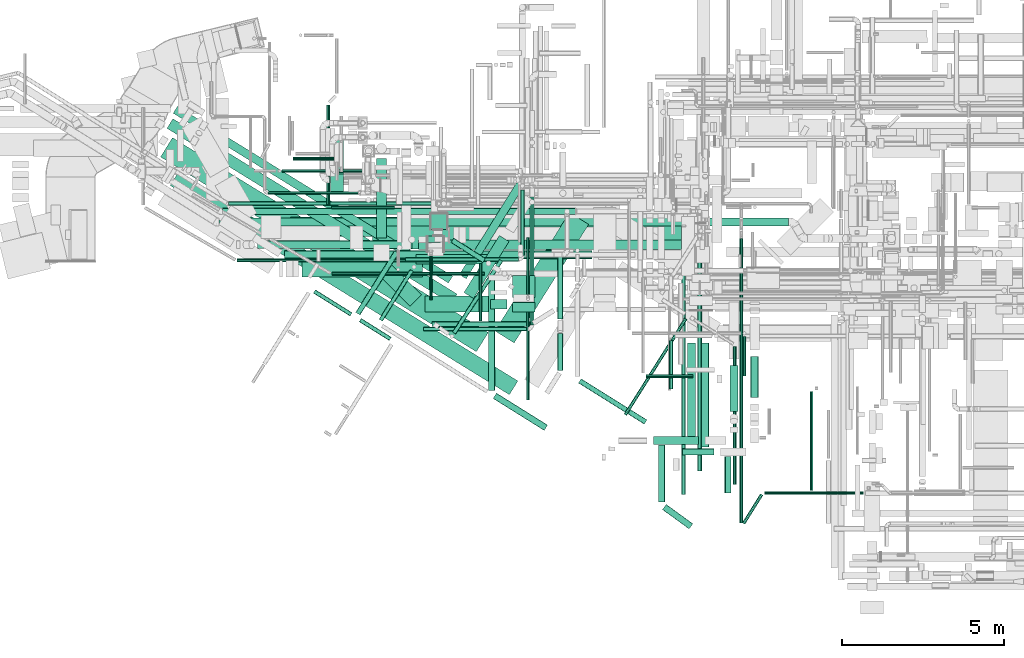
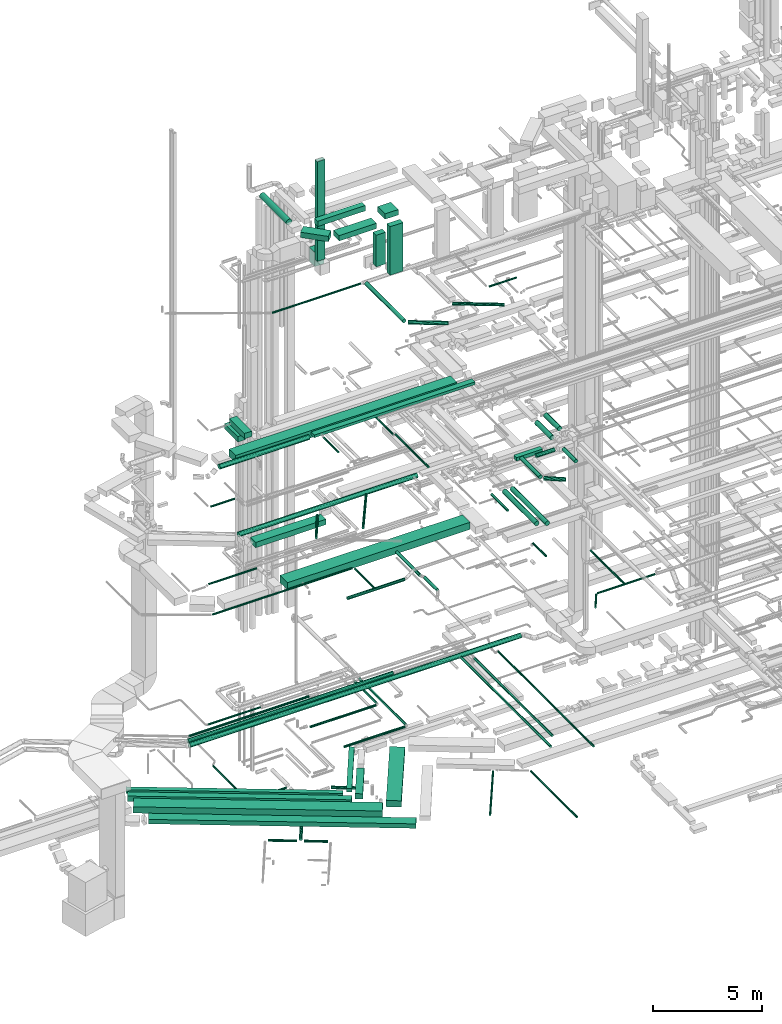
# One storey, part 25 of 337: 74 flow segments.
"""IFC2X3 building model written with IfcOpenShell, lengths in millimetres."""

from ifc_helpers import new_model, entity, si_unit, converted_unit, derived_unit, direction, frame, origin, origin_2d_with_axis, place, context, subcontext, project, spatial, rectangle, circle, extrude, type_object, element, save


model = new_model("IFC2X3")

# Units and contexts
model_context = context("Model", 3, precision=0.01, world=origin(), true_north=direction((6.12303176911189e-17, 1.0)))
body_context = subcontext(model_context, "Body", "Model", "MODEL_VIEW")
ifc_project = project(units=[si_unit("LENGTHUNIT", "METRE", prefix="MILLI"), si_unit("AREAUNIT", "SQUARE_METRE"), si_unit("VOLUMEUNIT", "CUBIC_METRE"), converted_unit("PLANEANGLEUNIT", "DEGREE", entity("IfcRatioMeasure", 0.0174532925199433), si_unit("PLANEANGLEUNIT", "RADIAN"), dimensions=[0, 0, 0, 0, 0, 0, 0]), si_unit("MASSUNIT", "GRAM", prefix="KILO"), derived_unit("MASSDENSITYUNIT", [(si_unit("MASSUNIT", "GRAM", prefix="KILO"), 1), (si_unit("LENGTHUNIT", "METRE"), -3)]), derived_unit("MOMENTOFINERTIAUNIT", [(si_unit("LENGTHUNIT", "METRE"), 4)]), si_unit("TIMEUNIT", "SECOND"), si_unit("FREQUENCYUNIT", "HERTZ"), si_unit("THERMODYNAMICTEMPERATUREUNIT", "DEGREE_CELSIUS"), derived_unit("THERMALTRANSMITTANCEUNIT", [(si_unit("MASSUNIT", "GRAM", prefix="KILO"), 1), (si_unit("THERMODYNAMICTEMPERATUREUNIT", "KELVIN"), -1), (si_unit("TIMEUNIT", "SECOND"), -3)]), derived_unit("VOLUMETRICFLOWRATEUNIT", [(si_unit("LENGTHUNIT", "METRE"), 3), (si_unit("TIMEUNIT", "SECOND"), -1)]), derived_unit("MASSFLOWRATEUNIT", [(si_unit("MASSUNIT", "GRAM", prefix="KILO"), 1), (si_unit("TIMEUNIT", "SECOND"), -1)]), derived_unit("ROTATIONALFREQUENCYUNIT", [(si_unit("TIMEUNIT", "SECOND"), -1)]), si_unit("ELECTRICCURRENTUNIT", "AMPERE"), si_unit("ELECTRICVOLTAGEUNIT", "VOLT"), si_unit("POWERUNIT", "WATT"), si_unit("FORCEUNIT", "NEWTON", prefix="KILO"), si_unit("ILLUMINANCEUNIT", "LUX"), si_unit("LUMINOUSFLUXUNIT", "LUMEN"), si_unit("LUMINOUSINTENSITYUNIT", "CANDELA"), derived_unit("USERDEFINED", [(si_unit("MASSUNIT", "GRAM", prefix="KILO"), -1), (si_unit("LENGTHUNIT", "METRE"), -2), (si_unit("TIMEUNIT", "SECOND"), 3), (si_unit("LUMINOUSFLUXUNIT", "LUMEN"), 1)]), derived_unit("LINEARVELOCITYUNIT", [(si_unit("LENGTHUNIT", "METRE"), 1), (si_unit("TIMEUNIT", "SECOND"), -1)]), si_unit("PRESSUREUNIT", "PASCAL"), derived_unit("USERDEFINED", [(si_unit("LENGTHUNIT", "METRE"), -2), (si_unit("MASSUNIT", "GRAM", prefix="KILO"), 1), (si_unit("TIMEUNIT", "SECOND"), -2)]), derived_unit("LINEARFORCEUNIT", [(si_unit("MASSUNIT", "GRAM", prefix="KILO"), 1), (si_unit("LENGTHUNIT", "METRE"), 1), (si_unit("TIMEUNIT", "SECOND"), -2), (si_unit("LENGTHUNIT", "METRE"), -1)]), derived_unit("PLANARFORCEUNIT", [(si_unit("MASSUNIT", "GRAM", prefix="KILO"), 1), (si_unit("LENGTHUNIT", "METRE"), 1), (si_unit("TIMEUNIT", "SECOND"), -2), (si_unit("LENGTHUNIT", "METRE"), -2)])], contexts=[model_context])

# Site, building, storey
site_placement = place(None, origin())
site = spatial("IfcSite", under=ifc_project, at=site_placement, CompositionType="ELEMENT")
building_placement = place(site_placement, origin())
building = spatial("IfcBuilding", under=site, at=building_placement, CompositionType="ELEMENT")
storey_placement = place(building_placement, origin())
storey = spatial("IfcBuildingStorey", under=building, at=storey_placement, CompositionType="ELEMENT", Elevation=0.0)

# Flow segments
duct_segment_type_1 = type_object("IfcDuctSegmentType", PredefinedType="NOTDEFINED")
flow_segment_1_placement = place(storey_placement, frame((1781.01, 7739.37, -800.0)))
element("IfcFlowSegment", 1, at=flow_segment_1_placement, inside=storey, type_object=duct_segment_type_1, context=body_context, shape_type="SweptSolid", body=[
    extrude(rectangle(XDim=11454.2887651558, YDim=699.999999999998, at=origin_2d_with_axis()), frame((5058.07, 3304.76, 0.0), z_axis=(0.0, 0.0, 1.0), x_axis=(-0.851088797264639, 0.525021770187323, 0.0)), (0.0, 0.0, 1.0), 350.0),
])
flow_segment_2_placement = place(storey_placement, frame((1978.11, 9221.71, -750.0)))
element("IfcFlowSegment", 2, at=flow_segment_2_placement, inside=storey, type_object=duct_segment_type_1, context=body_context, shape_type="SweptSolid", body=[
    extrude(rectangle(XDim=10312.3007437821, YDim=350.000000000001, at=origin_2d_with_axis()), frame((4480.22, 2856.03, 0.0), z_axis=(0.0, 0.0, 1.0), x_axis=(-0.85108880635298, 0.525021755454628, 0.0)), (0.0, 0.0, 1.0), 300.0),
])
flow_segment_3_placement = place(storey_placement, frame((11144.59, 9383.01, -750.0)))
element("IfcFlowSegment", 3, at=flow_segment_3_placement, inside=storey, type_object=duct_segment_type_1, context=body_context, shape_type="SweptSolid", body=[
    extrude(rectangle(XDim=2073.56434596333, YDim=350.000000000001, at=origin_2d_with_axis()), frame((696.54, 972.63, 0.0), z_axis=(0.0, 0.0, 1.0), x_axis=(0.52854381603038, 0.848906022205075, 0.0)), (0.0, 0.0, 1.0), 300.0),
])
flow_segment_4_placement = place(storey_placement, frame((12102.86, 8010.17, -800.0)))
element("IfcFlowSegment", 4, at=flow_segment_4_placement, inside=storey, type_object=duct_segment_type_1, context=body_context, shape_type="SweptSolid", body=[
    extrude(rectangle(XDim=4322.66331644128, YDim=700.000000000002, at=origin_2d_with_axis()), frame((1447.16, 2015.79, 0.0), z_axis=(0.0, 0.0, 1.0), x_axis=(0.532501705463199, 0.846428930081424, 0.0)), (0.0, 0.0, 1.0), 350.0),
])
flow_segment_5_placement = place(storey_placement, frame((2170.93, 9861.12, -650.0)))
element("IfcFlowSegment", 5, at=flow_segment_5_placement, inside=storey, type_object=duct_segment_type_1, context=body_context, shape_type="SweptSolid", body=[
    extrude(rectangle(XDim=9982.84701585936, YDim=250.0, at=origin_2d_with_axis()), frame((4313.77, 2726.99, 0.0), z_axis=(0.0, 0.0, 1.0), x_axis=(-0.85108880635298, 0.525021755454629, 0.0)), (0.0, 0.0, 1.0), 200.0),
])
flow_segment_6_placement = place(storey_placement, frame((11004.56, 9990.14, -650.0)))
element("IfcFlowSegment", 6, at=flow_segment_6_placement, inside=storey, type_object=duct_segment_type_1, context=body_context, shape_type="SweptSolid", body=[
    extrude(rectangle(XDim=3355.15981218457, YDim=249.999999999999, at=origin_2d_with_axis()), frame((992.79, 1490.18, 0.0), z_axis=(0.0, 0.0, 1.0), x_axis=(0.528543816030324, 0.84890602220511, 0.0)), (0.0, 0.0, 1.0), 200.0),
])
flow_segment_7_placement = place(storey_placement, frame((8328.34, 10917.22, 11150.0)))
element("IfcFlowSegment", 7, at=flow_segment_7_placement, inside=storey, type_object=duct_segment_type_1, context=body_context, shape_type="SweptSolid", body=[
    extrude(rectangle(XDim=9693.4743474531, YDim=700.000000000001, at=origin_2d_with_axis()), frame((4846.74, 350.0, 0.0), z_axis=(0.0, 0.0, 1.0), x_axis=(-1.0, 0.0, 0.0)), (0.0, 0.0, 1.0), 400.0),
])
flow_segment_8_placement = place(storey_placement, frame((5791.73, 11292.03, 18950.0)))
element("IfcFlowSegment", 8, at=flow_segment_8_placement, inside=storey, type_object=duct_segment_type_1, context=body_context, shape_type="SweptSolid", body=[
    extrude(rectangle(XDim=11757.7503471403, YDim=600.0, at=origin_2d_with_axis()), frame((5878.88, 300.0, 0.0), z_axis=(0.0, 0.0, 1.0), x_axis=(-1.0, 0.0, 0.0)), (0.0, 0.0, 1.0), 400.0),
])
flow_segment_9_placement = place(storey_placement, frame((7024.85, 12617.41, 19050.0)))
element("IfcFlowSegment", 9, at=flow_segment_9_placement, inside=storey, type_object=duct_segment_type_1, context=body_context, shape_type="SweptSolid", body=[
    extrude(rectangle(XDim=1391.87500000003, YDim=400.0, at=origin_2d_with_axis()), frame((200.0, 695.94, 0.0), z_axis=(0.0, 0.0, 1.0), x_axis=(0.0, -1.0, 0.0)), (0.0, 0.0, 1.0), 300.000000000001),
])
flow_segment_10_placement = place(storey_placement, frame((17001.36, 4874.06, 19000.0)))
element("IfcFlowSegment", 10, at=flow_segment_10_placement, inside=storey, type_object=duct_segment_type_1, context=body_context, shape_type="SweptSolid", body=[
    extrude(rectangle(XDim=1380.0, YDim=250.000000000001, at=origin_2d_with_axis()), frame((690.0, 125.0, 0.0), z_axis=(0.0, 0.0, 1.0), x_axis=(-1.0, 0.0, 0.0)), (0.0, 0.0, 1.0), 199.999999999998),
])
flow_segment_11_placement = place(storey_placement, frame((6148.71, 10049.62, 14800.0)))
element("IfcFlowSegment", 11, at=flow_segment_11_placement, inside=storey, type_object=duct_segment_type_1, context=body_context, shape_type="SweptSolid", body=[
    extrude(rectangle(XDim=3719.46663347353, YDim=499.999999999999, at=origin_2d_with_axis()), frame((1859.73, 250.0, 0.0)), (0.0, 0.0, 1.0), 300.000000000001),
])
flow_segment_12_placement = place(storey_placement, frame((7025.26, 13228.06, 18500.0)))
element("IfcFlowSegment", 12, at=flow_segment_12_placement, inside=storey, type_object=duct_segment_type_1, context=body_context, shape_type="SweptSolid", body=[
    extrude(rectangle(XDim=1222.50000000004, YDim=400.0, at=origin_2d_with_axis()), frame((200.0, 611.25, 0.0), z_axis=(0.0, 0.0, 1.0), x_axis=(0.0, -1.0, 0.0)), (0.0, 0.0, 1.0), 300.000000000001),
])
flow_segment_13_placement = place(storey_placement, frame((9739.35, 10896.76, 19200.0)))
element("IfcFlowSegment", 13, at=flow_segment_13_placement, inside=storey, type_object=duct_segment_type_1, context=body_context, shape_type="SweptSolid", body=[
    extrude(rectangle(XDim=8535.95393315093, YDim=299.999999999999, at=origin_2d_with_axis()), frame((4267.98, 150.0, 0.0)), (0.0, 0.0, 1.0), 150.000000000001),
])
flow_segment_14_placement = place(storey_placement, frame((11967.8, 9059.89, 29122.0)))
element("IfcFlowSegment", 14, at=flow_segment_14_placement, inside=storey, type_object=duct_segment_type_1, context=body_context, shape_type="SweptSolid", body=[
    extrude(rectangle(XDim=299.999999999999, YDim=500.000000000001, at=origin_2d_with_axis()), frame((250.0, 150.0, 0.0), z_axis=(0.0, 0.0, 1.0), x_axis=(0.0, 1.0, 0.0)), (0.0, 0.0, 1.0), 1778.00000000006),
])
flow_segment_15_placement = place(storey_placement, frame((9939.57, 8959.89, 31350.0)))
element("IfcFlowSegment", 15, at=flow_segment_15_placement, inside=storey, type_object=duct_segment_type_1, context=body_context, shape_type="SweptSolid", body=[
    extrude(rectangle(XDim=1978.23387247989, YDim=500.0, at=origin_2d_with_axis()), frame((989.12, 250.0, 0.0), z_axis=(0.0, 0.0, 1.0), x_axis=(-1.0, 0.0, 0.0)), (0.0, 0.0, 1.0), 300.000000000001),
])
flow_segment_16_placement = place(storey_placement, frame((8541.79, 9150.27, 31350.0)))
element("IfcFlowSegment", 16, at=flow_segment_16_placement, inside=storey, type_object=duct_segment_type_1, context=body_context, shape_type="SweptSolid", body=[
    extrude(rectangle(XDim=1326.75631164926, YDim=500.0, at=origin_2d_with_axis()), frame((645.86, 645.86, 0.0), z_axis=(0.0, 0.0, 1.0), x_axis=(-0.707106781186546, 0.707106781186549, 0.0)), (0.0, 0.0, 1.0), 300.000000000001),
])
flow_segment_17_placement = place(storey_placement, frame((10123.64, 11511.11, 28300.0)))
element("IfcFlowSegment", 17, at=flow_segment_17_placement, inside=storey, type_object=duct_segment_type_1, context=body_context, shape_type="SweptSolid", body=[
    extrude(rectangle(XDim=499.999999999999, YDim=499.999999999999, at=origin_2d_with_axis()), frame((250.0, 250.0, 0.0)), (0.0, 0.0, 1.0), 800.0),
])
flow_segment_18_placement = place(storey_placement, frame((10023.38, 11111.11, 28870.0)))
element("IfcFlowSegment", 18, at=flow_segment_18_placement, inside=storey, type_object=duct_segment_type_1, context=body_context, shape_type="SweptSolid", body=[
    extrude(rectangle(XDim=400.0, YDim=200.0, at=origin_2d_with_axis()), frame((200.0, 100.0, 0.0), z_axis=(0.0, 0.0, 1.0), x_axis=(-1.0, 0.0, 0.0)), (0.0, 0.0, 1.0), 5590.0),
])
flow_segment_19_placement = place(storey_placement, frame((2078.18, 6413.05, -975.0)))
element("IfcFlowSegment", 19, at=flow_segment_19_placement, inside=storey, type_object=duct_segment_type_1, context=body_context, shape_type="SweptSolid", body=[
    extrude(rectangle(XDim=12302.7306166602, YDim=500.0, at=origin_2d_with_axis()), frame((5366.61, 3442.37, 0.0), z_axis=(0.0, 0.0, 1.0), x_axis=(-0.851088806352981, 0.525021755454626, 0.0)), (0.0, 0.0, 1.0), 250.0),
])
duct_segment_type_2 = type_object("IfcDuctSegmentType", PredefinedType="NOTDEFINED")
flow_segment_20_placement = place(storey_placement, frame((10744.77, 10486.01, -1031.6)))
element("IfcFlowSegment", 20, at=flow_segment_20_placement, inside=storey, type_object=duct_segment_type_2, context=body_context, shape_type="SweptSolid", body=[
    extrude(circle(Radius=80.0, at=origin_2d_with_axis()), frame((1022.5, 69.02, 81.6), z_axis=(-0.842777865146122, 0.538261525672925, 0.0), x_axis=(0.538261525672925, 0.842777865146122, 0.0)), (0.0, 0.0, 1.0), 1160.26481978889),
])
flow_segment_21_placement = place(storey_placement, frame((19451.45, 3639.51, -1151.6)))
element("IfcFlowSegment", 21, at=flow_segment_21_placement, inside=storey, type_object=duct_segment_type_2, context=body_context, shape_type="SweptSolid", body=[
    extrude(circle(Radius=50.0, at=origin_2d_with_axis()), frame((51.6, 0.0, 51.6), z_axis=(0.0, 1.0, 0.0), x_axis=(-1.0, 0.0, 0.0)), (0.0, 0.0, 1.0), 4257.58159541827),
])
flow_segment_22_placement = place(storey_placement, frame((16081.58, 5765.98, -1151.6)))
element("IfcFlowSegment", 22, at=flow_segment_22_placement, inside=storey, type_object=duct_segment_type_2, context=body_context, shape_type="SweptSolid", body=[
    extrude(circle(Radius=50.0, at=origin_2d_with_axis()), frame((43.89, 28.26, 51.6), z_axis=(0.533247984219863, 0.845958974965957, 0.0), x_axis=(-0.845958974965957, 0.533247984219863, 0.0)), (0.0, 0.0, 1.0), 3507.69298208953),
])
flow_segment_23_placement = place(storey_placement, frame((7054.03, 12138.59, -1001.6)))
element("IfcFlowSegment", 23, at=flow_segment_23_placement, inside=storey, type_object=duct_segment_type_2, context=body_context, shape_type="SweptSolid", body=[
    extrude(circle(Radius=50.0, at=origin_2d_with_axis()), frame((0.0, 51.6, 51.6), z_axis=(1.0, 0.0, 0.0), x_axis=(0.0, 1.0, 0.0)), (0.0, 0.0, 1.0), 1949.21744000001),
])
flow_segment_24_placement = place(storey_placement, frame((6902.44, 12290.19, -1001.6)))
element("IfcFlowSegment", 24, at=flow_segment_24_placement, inside=storey, type_object=duct_segment_type_2, context=body_context, shape_type="SweptSolid", body=[
    extrude(circle(Radius=50.0, at=origin_2d_with_axis()), frame((51.6, 0.0, 51.6), z_axis=(0.0, 1.0, 0.0), x_axis=(1.0, 0.0, 0.0)), (0.0, 0.0, 1.0), 3071.9800537627),
])
flow_segment_25_placement = place(storey_placement, frame((7802.27, 8871.08, -1551.6)))
element("IfcFlowSegment", 25, at=flow_segment_25_placement, inside=storey, type_object=duct_segment_type_2, context=body_context, shape_type="SweptSolid", body=[
    extrude(circle(Radius=80.0, at=origin_2d_with_axis()), frame((69.31, 44.2, 81.6), z_axis=(0.532501705463199, 0.846428930081424, 0.0), x_axis=(0.846428930081424, -0.532501705463199, 0.0)), (0.0, 0.0, 1.0), 2246.71858714533),
])
flow_segment_26_placement = place(storey_placement, frame((6494.0, 8837.87, -1534.1)))
element("IfcFlowSegment", 26, at=flow_segment_26_placement, inside=storey, type_object=duct_segment_type_2, context=body_context, shape_type="SweptSolid", body=[
    extrude(circle(Radius=62.5, at=origin_2d_with_axis()), frame((34.71, 763.21, 64.1), z_axis=(0.848052743777572, -0.529911826412028, 0.0), x_axis=(0.529911826412028, 0.848052743777572, 0.0)), (0.0, 0.0, 1.0), 1337.2303245543),
])
flow_segment_27_placement = place(storey_placement, frame((7907.9, 8082.02, -1534.1)))
element("IfcFlowSegment", 27, at=flow_segment_27_placement, inside=storey, type_object=duct_segment_type_2, context=body_context, shape_type="SweptSolid", body=[
    extrude(circle(Radius=62.5, at=origin_2d_with_axis()), frame((34.71, 635.58, 64.1), z_axis=(0.848052743777565, -0.529911826412039, 0.0), x_axis=(-0.529911826412039, -0.848052743777565, 0.0)), (0.0, 0.0, 1.0), 1096.37662800055),
])
flow_segment_28_placement = place(storey_placement, frame((11602.42, 8692.96, 11398.4)))
element("IfcFlowSegment", 28, at=flow_segment_28_placement, inside=storey, type_object=duct_segment_type_2, context=body_context, shape_type="SweptSolid", body=[
    extrude(circle(Radius=50.0, at=origin_2d_with_axis()), frame((51.6, 0.0, 51.6), z_axis=(0.0, 1.0, 0.0), x_axis=(-1.0, 0.0, 0.0)), (0.0, 0.0, 1.0), 1768.54994382471),
])
flow_segment_29_placement = place(storey_placement, frame((4140.81, 10509.92, 11398.4)))
element("IfcFlowSegment", 29, at=flow_segment_29_placement, inside=storey, type_object=duct_segment_type_2, context=body_context, shape_type="SweptSolid", body=[
    extrude(circle(Radius=50.0, at=origin_2d_with_axis()), frame((0.0, 51.6, 51.6), z_axis=(1.0, 0.0, 0.0), x_axis=(0.0, 1.0, 0.0)), (0.0, 0.0, 1.0), 7413.20508075711),
])
flow_segment_30_placement = place(storey_placement, frame((14036.34, 7167.28, 11318.4)))
element("IfcFlowSegment", 30, at=flow_segment_30_placement, inside=storey, type_object=duct_segment_type_2, context=body_context, shape_type="SweptSolid", body=[
    extrude(circle(Radius=80.0, at=origin_2d_with_axis()), frame((81.6, 0.0, 81.6), z_axis=(0.0, 1.0, 0.0), x_axis=(-1.0, 0.0, 0.0)), (0.0, 0.0, 1.0), 1138.27260044521),
])
flow_segment_31_placement = place(storey_placement, frame((20422.67, 3328.95, 11248.4)))
element("IfcFlowSegment", 31, at=flow_segment_31_placement, inside=storey, type_object=duct_segment_type_2, context=body_context, shape_type="SweptSolid", body=[
    extrude(circle(Radius=50.0, at=origin_2d_with_axis()), frame((0.0, 51.6, 51.6), z_axis=(1.0, 0.0, 0.0), x_axis=(0.0, -1.0, 0.0)), (0.0, 0.0, 1.0), 3054.62565881222),
])
flow_segment_32_placement = place(storey_placement, frame((19734.57, 2410.36, 11248.4)))
element("IfcFlowSegment", 32, at=flow_segment_32_placement, inside=storey, type_object=duct_segment_type_2, context=body_context, shape_type="SweptSolid", body=[
    extrude(circle(Radius=50.0, at=origin_2d_with_axis()), frame((44.0, 28.09, 51.6), z_axis=(0.529911826411992, 0.848052743777595, 0.0), x_axis=(-0.848052743777595, 0.529911826411992, 0.0)), (0.0, 0.0, 1.0), 1055.45839552251),
])
flow_segment_33_placement = place(storey_placement, frame((21824.3, 3450.54, 11248.4)))
element("IfcFlowSegment", 33, at=flow_segment_33_placement, inside=storey, type_object=duct_segment_type_2, context=body_context, shape_type="SweptSolid", body=[
    extrude(circle(Radius=50.0, at=origin_2d_with_axis()), frame((51.6, 0.0, 51.6), z_axis=(0.0, 1.0, 0.0), x_axis=(-1.0, 0.0, 0.0)), (0.0, 0.0, 1.0), 3060.00000000001),
])
flow_segment_34_placement = place(storey_placement, frame((8523.71, 8678.98, 15260.9)))
element("IfcFlowSegment", 34, at=flow_segment_34_placement, inside=storey, type_object=duct_segment_type_2, context=body_context, shape_type="SweptSolid", body=[
    extrude(circle(Radius=62.5, at=origin_2d_with_axis()), frame((54.64, 34.65, 64.1), z_axis=(0.528858260761643, 0.848710162555021, 0.0), x_axis=(0.848710162555021, -0.528858260761643, 0.0)), (0.0, 0.0, 1.0), 1809.94829410788),
])
flow_segment_35_placement = place(storey_placement, frame((3881.65, 12246.26, 3585.9)))
element("IfcFlowSegment", 35, at=flow_segment_35_placement, inside=storey, type_object=duct_segment_type_2, context=body_context, shape_type="SweptSolid", body=[
    extrude(circle(Radius=62.5, at=origin_2d_with_axis()), frame((0.0, 64.1, 64.1), z_axis=(1.0, 0.0, 0.0), x_axis=(0.0, -1.0, 0.0)), (0.0, 0.0, 1.0), 6386.12217164964),
])
flow_segment_36_placement = place(storey_placement, frame((19653.1, 2456.09, 3468.4)))
element("IfcFlowSegment", 36, at=flow_segment_36_placement, inside=storey, type_object=duct_segment_type_2, context=body_context, shape_type="SweptSolid", body=[
    extrude(circle(Radius=50.0, at=origin_2d_with_axis()), frame((51.6, 0.0, 51.6), z_axis=(0.0, 1.0, 0.0), x_axis=(-1.0, 0.0, 0.0)), (0.0, 0.0, 1.0), 8778.5786437627),
])
flow_segment_37_placement = place(storey_placement, frame((3587.15, 11617.53, 3473.4)))
element("IfcFlowSegment", 37, at=flow_segment_37_placement, inside=storey, type_object=duct_segment_type_2, context=body_context, shape_type="SweptSolid", body=[
    extrude(circle(Radius=125.0, at=origin_2d_with_axis()), frame((0.0, 126.6, 126.6), z_axis=(1.0, 0.0, 0.0), x_axis=(0.0, -1.0, 0.0)), (0.0, 0.0, 1.0), 17583.9772727151),
])
flow_segment_38_placement = place(storey_placement, frame((17863.34, 3339.78, 3535.9)))
element("IfcFlowSegment", 38, at=flow_segment_38_placement, inside=storey, type_object=duct_segment_type_2, context=body_context, shape_type="SweptSolid", body=[
    extrude(circle(Radius=62.5, at=origin_2d_with_axis()), frame((64.1, 0.0, 64.1), z_axis=(0.0, 1.0, 0.0), x_axis=(-1.0, 0.0, 0.0)), (0.0, 0.0, 1.0), 8259.34554176387),
])
flow_segment_39_placement = place(storey_placement, frame((5534.47, 13264.09, 10948.4)))
element("IfcFlowSegment", 39, at=flow_segment_39_placement, inside=storey, type_object=duct_segment_type_2, context=body_context, shape_type="SweptSolid", body=[
    extrude(circle(Radius=50.0, at=origin_2d_with_axis()), frame((0.0, 51.6, 51.6), z_axis=(1.0, 0.0, 0.0), x_axis=(0.0, 1.0, 0.0)), (0.0, 0.0, 1.0), 2542.85863829996),
])
flow_segment_40_placement = place(storey_placement, frame((19748.51, 6990.47, 11348.4)))
element("IfcFlowSegment", 40, at=flow_segment_40_placement, inside=storey, type_object=duct_segment_type_2, context=body_context, shape_type="SweptSolid", body=[
    extrude(circle(Radius=50.0, at=origin_2d_with_axis()), frame((51.6, 0.0, 51.6), z_axis=(0.0, 1.0, 0.0), x_axis=(1.0, 0.0, 0.0)), (0.0, 0.0, 1.0), 1220.00000000002),
])
flow_segment_41_placement = place(storey_placement, frame((3689.15, 11972.94, 3498.4)))
element("IfcFlowSegment", 41, at=flow_segment_41_placement, inside=storey, type_object=duct_segment_type_2, context=body_context, shape_type="SweptSolid", body=[
    extrude(circle(Radius=100.0, at=origin_2d_with_axis()), frame((0.0, 101.6, 101.6), z_axis=(1.0, 0.0, 0.0), x_axis=(0.0, 1.0, 0.0)), (0.0, 0.0, 1.0), 10894.9493972496),
])
flow_segment_42_placement = place(storey_placement, frame((18360.0, 4060.08, 3535.9)))
element("IfcFlowSegment", 42, at=flow_segment_42_placement, inside=storey, type_object=duct_segment_type_2, context=body_context, shape_type="SweptSolid", body=[
    extrude(circle(Radius=62.5, at=origin_2d_with_axis()), frame((64.1, 0.0, 64.1), z_axis=(0.0, 1.0, 0.0), x_axis=(-1.0, 0.0, 0.0)), (0.0, 0.0, 1.0), 7135.00000000001),
])
flow_segment_43_placement = place(storey_placement, frame((13182.54, 8563.59, 3235.9)))
element("IfcFlowSegment", 43, at=flow_segment_43_placement, inside=storey, type_object=duct_segment_type_2, context=body_context, shape_type="SweptSolid", body=[
    extrude(circle(Radius=62.5, at=origin_2d_with_axis()), frame((64.1, 0.0, 64.1), z_axis=(0.0, 1.0, 0.0), x_axis=(1.0, 0.0, 0.0)), (0.0, 0.0, 1.0), 4236.24999999994),
])
flow_segment_44_placement = place(storey_placement, frame((9901.63, 8374.5, 3235.9)))
element("IfcFlowSegment", 44, at=flow_segment_44_placement, inside=storey, type_object=duct_segment_type_2, context=body_context, shape_type="SweptSolid", body=[
    extrude(circle(Radius=62.5, at=origin_2d_with_axis()), frame((0.0, 64.1, 64.1), z_axis=(1.0, 0.0, 0.0), x_axis=(0.0, 1.0, 0.0)), (0.0, 0.0, 1.0), 3220.0),
])
flow_segment_45_placement = place(storey_placement, frame((5097.19, 12586.23, 3628.4)))
element("IfcFlowSegment", 45, at=flow_segment_45_placement, inside=storey, type_object=duct_segment_type_2, context=body_context, shape_type="SweptSolid", body=[
    extrude(circle(Radius=50.0, at=origin_2d_with_axis()), frame((0.0, 51.6, 51.6), z_axis=(1.0, 0.0, 0.0), x_axis=(0.0, -1.0, 0.0)), (0.0, 0.0, 1.0), 2792.50000000001),
])
flow_segment_46_placement = place(storey_placement, frame((10162.95, 8511.37, 11368.4)))
element("IfcFlowSegment", 46, at=flow_segment_46_placement, inside=storey, type_object=duct_segment_type_2, context=body_context, shape_type="SweptSolid", body=[
    extrude(circle(Radius=80.0, at=origin_2d_with_axis()), frame((0.0, 81.6, 81.6), z_axis=(1.0, 0.0, 0.0), x_axis=(0.0, 1.0, 0.0)), (0.0, 0.0, 1.0), 3034.12073827859),
])
flow_segment_47_placement = place(storey_placement, frame((5863.32, 13648.4, 14948.4)))
element("IfcFlowSegment", 47, at=flow_segment_47_placement, inside=storey, type_object=duct_segment_type_2, context=body_context, shape_type="SweptSolid", body=[
    extrude(circle(Radius=50.0, at=origin_2d_with_axis()), frame((0.0, 51.6, 51.6), z_axis=(1.0, 0.0, 0.0), x_axis=(0.0, -1.0, 0.0)), (0.0, 0.0, 1.0), 1266.00000000001),
])
flow_segment_48_placement = place(storey_placement, frame((18465.04, 4797.3, 14873.4)))
element("IfcFlowSegment", 48, at=flow_segment_48_placement, inside=storey, type_object=duct_segment_type_2, context=body_context, shape_type="SweptSolid", body=[
    extrude(circle(Radius=125.0, at=origin_2d_with_axis()), frame((126.6, 0.0, 126.6), z_axis=(0.0, 1.0, 0.0), x_axis=(-1.0, 0.0, 0.0)), (0.0, 0.0, 1.0), 3217.85129907237),
])
flow_segment_49_placement = place(storey_placement, frame((18043.16, 5034.74, 14873.4)))
element("IfcFlowSegment", 49, at=flow_segment_49_placement, inside=storey, type_object=duct_segment_type_2, context=body_context, shape_type="SweptSolid", body=[
    extrude(circle(Radius=125.0, at=origin_2d_with_axis()), frame((126.6, 0.0, 126.6), z_axis=(0.0, 1.0, 0.0), x_axis=(-1.0, 0.0, 0.0)), (0.0, 0.0, 1.0), 2977.85129907236),
])
flow_segment_50_placement = place(storey_placement, frame((13073.16, 9513.45, 18998.4)))
element("IfcFlowSegment", 50, at=flow_segment_50_placement, inside=storey, type_object=duct_segment_type_2, context=body_context, shape_type="SweptSolid", body=[
    extrude(circle(Radius=50.0, at=origin_2d_with_axis()), frame((51.6, 0.0, 51.6), z_axis=(0.0, 1.0, 0.0), x_axis=(-1.0, 0.0, 0.0)), (0.0, 0.0, 1.0), 1758.57864376267),
])
flow_segment_51_placement = place(storey_placement, frame((4770.46, 10920.17, 19098.4)))
element("IfcFlowSegment", 51, at=flow_segment_51_placement, inside=storey, type_object=duct_segment_type_2, context=body_context, shape_type="SweptSolid", body=[
    extrude(circle(Radius=125.0, at=origin_2d_with_axis()), frame((0.0, 126.6, 126.6), z_axis=(1.0, 0.0, 0.0), x_axis=(0.0, 1.0, 0.0)), (0.0, 0.0, 1.0), 4768.88898255595),
])
flow_segment_52_placement = place(storey_placement, frame((10077.02, 9340.7, 19148.4)))
element("IfcFlowSegment", 52, at=flow_segment_52_placement, inside=storey, type_object=duct_segment_type_2, context=body_context, shape_type="SweptSolid", body=[
    extrude(circle(Radius=50.0, at=origin_2d_with_axis()), frame((51.6, 0.0, 51.6), z_axis=(0.0, 1.0, 0.0), x_axis=(-1.0, 0.0, 0.0)), (0.0, 0.0, 1.0), 1338.29472348829),
])
flow_segment_53_placement = place(storey_placement, frame((19993.44, 6320.46, 18723.4)))
element("IfcFlowSegment", 53, at=flow_segment_53_placement, inside=storey, type_object=duct_segment_type_2, context=body_context, shape_type="SweptSolid", body=[
    extrude(circle(Radius=125.0, at=origin_2d_with_axis()), frame((126.6, 0.0, 126.6), z_axis=(0.0, 1.0, 0.0), x_axis=(-1.0, 0.0, 0.0)), (0.0, 0.0, 1.0), 1269.99999999999),
])
flow_segment_54_placement = place(storey_placement, frame((17896.91, 4548.24, 19027.57)))
element("IfcFlowSegment", 54, at=flow_segment_54_placement, inside=storey, type_object=duct_segment_type_2, context=body_context, shape_type="SweptSolid", body=[
    extrude(circle(Radius=100.0, at=origin_2d_with_axis()), frame((0.0, 101.6, 101.6), z_axis=(1.0, 0.0, 0.0), x_axis=(0.0, 1.0, 0.0)), (0.0, 0.0, 1.0), 970.137788127613),
])
flow_segment_55_placement = place(storey_placement, frame((19193.6, 3384.84, 18998.4)))
element("IfcFlowSegment", 55, at=flow_segment_55_placement, inside=storey, type_object=duct_segment_type_2, context=body_context, shape_type="SweptSolid", body=[
    extrude(circle(Radius=100.0, at=origin_2d_with_axis()), frame((101.6, 0.0, 101.6), z_axis=(0.0, 1.0, 0.0), x_axis=(-1.0, 0.0, 0.0)), (0.0, 0.0, 1.0), 1119.99999999999),
])
flow_segment_56_placement = place(storey_placement, frame((19354.77, 5902.62, 18698.4)))
element("IfcFlowSegment", 56, at=flow_segment_56_placement, inside=storey, type_object=duct_segment_type_2, context=body_context, shape_type="SweptSolid", body=[
    extrude(circle(Radius=125.0, at=origin_2d_with_axis()), frame((126.6, 0.0, 126.6), z_axis=(0.0, 1.0, 0.0), x_axis=(-1.0, 0.0, 0.0)), (0.0, 0.0, 1.0), 1406.4466094067),
])
flow_segment_57_placement = place(storey_placement, frame((17148.06, 3109.19, 18998.4)))
element("IfcFlowSegment", 57, at=flow_segment_57_placement, inside=storey, type_object=duct_segment_type_2, context=body_context, shape_type="SweptSolid", body=[
    extrude(circle(Radius=100.0, at=origin_2d_with_axis()), frame((101.6, 0.0, 101.6), z_axis=(0.0, 1.0, 0.0), x_axis=(-1.0, 0.0, 0.0)), (0.0, 0.0, 1.0), 1744.87612558139),
])
flow_segment_58_placement = place(storey_placement, frame((17271.72, 2267.98, 18998.4)))
element("IfcFlowSegment", 58, at=flow_segment_58_placement, inside=storey, type_object=duct_segment_type_2, context=body_context, shape_type="SweptSolid", body=[
    extrude(circle(Radius=100.0, at=origin_2d_with_axis()), frame((881.95, 82.5, 101.6), z_axis=(-0.809016994374953, 0.587785252292466, 0.0), x_axis=(-0.587785252292466, -0.809016994374953, 0.0)), (0.0, 0.0, 1.0), 1015.5189687402),
])
flow_segment_59_placement = place(storey_placement, frame((14036.34, 8755.63, 11168.4)))
element("IfcFlowSegment", 59, at=flow_segment_59_placement, inside=storey, type_object=duct_segment_type_2, context=body_context, shape_type="SweptSolid", body=[
    extrude(circle(Radius=80.0, at=origin_2d_with_axis()), frame((81.6, 0.0, 81.6), z_axis=(0.0, 1.0, 0.0), x_axis=(-1.0, 0.0, 0.0)), (0.0, 0.0, 1.0), 2141.58958427224),
])
flow_segment_60_placement = place(storey_placement, frame((5607.5, 10608.04, 15198.4)))
element("IfcFlowSegment", 60, at=flow_segment_60_placement, inside=storey, type_object=duct_segment_type_2, context=body_context, shape_type="SweptSolid", body=[
    extrude(circle(Radius=125.0, at=origin_2d_with_axis()), frame((0.0, 126.6, 126.6), z_axis=(1.0, 0.0, 0.0), x_axis=(0.0, -1.0, 0.0)), (0.0, 0.0, 1.0), 9485.39606180322),
])
flow_segment_61_placement = place(storey_placement, frame((10786.9, 8283.61, 15260.9)))
element("IfcFlowSegment", 61, at=flow_segment_61_placement, inside=storey, type_object=duct_segment_type_2, context=body_context, shape_type="SweptSolid", body=[
    extrude(circle(Radius=62.5, at=origin_2d_with_axis()), frame((54.01, 35.64, 64.1), z_axis=(0.544639035015033, 0.838670567945421, 0.0), x_axis=(0.838670567945421, -0.544639035015033, 0.0)), (0.0, 0.0, 1.0), 2670.3836164577),
])
flow_segment_62_placement = place(storey_placement, frame((17471.46, 6596.44, 14935.9)))
element("IfcFlowSegment", 62, at=flow_segment_62_placement, inside=storey, type_object=duct_segment_type_2, context=body_context, shape_type="SweptSolid", body=[
    extrude(circle(Radius=62.5, at=origin_2d_with_axis()), frame((64.1, 0.0, 64.1), z_axis=(0.0, 1.0, 0.0), x_axis=(-1.0, 0.0, 0.0)), (0.0, 0.0, 1.0), 1498.18619000042),
])
flow_segment_63_placement = place(storey_placement, frame((13073.16, 6250.61, 19139.83)))
element("IfcFlowSegment", 63, at=flow_segment_63_placement, inside=storey, type_object=duct_segment_type_2, context=body_context, shape_type="SweptSolid", body=[
    extrude(circle(Radius=50.0, at=origin_2d_with_axis()), frame((51.6, 0.0, 51.6), z_axis=(0.0, 1.0, 0.0), x_axis=(-1.0, 0.0, 0.0)), (0.0, 0.0, 1.0), 3038.57864376269),
])
flow_segment_64_placement = place(storey_placement, frame((7079.8, 10095.53, 27548.4)))
element("IfcFlowSegment", 64, at=flow_segment_64_placement, inside=storey, type_object=duct_segment_type_2, context=body_context, shape_type="SweptSolid", body=[
    extrude(circle(Radius=50.0, at=origin_2d_with_axis()), frame((0.0, 51.6, 51.6), z_axis=(1.0, 0.0, 0.0), x_axis=(0.0, 1.0, 0.0)), (0.0, 0.0, 1.0), 4695.13922089197),
])
flow_segment_65_placement = place(storey_placement, frame((11902.07, 6549.24, 27498.4)))
element("IfcFlowSegment", 65, at=flow_segment_65_placement, inside=storey, type_object=duct_segment_type_2, context=body_context, shape_type="SweptSolid", body=[
    extrude(circle(Radius=100.0, at=origin_2d_with_axis()), frame((101.6, 0.0, 101.6), z_axis=(0.0, 1.0, 0.0), x_axis=(-1.0, 0.0, 0.0)), (0.0, 0.0, 1.0), 3477.88847160694),
])
flow_segment_66_placement = place(storey_placement, frame((12043.1, 5307.1, 27498.4)))
element("IfcFlowSegment", 66, at=flow_segment_66_placement, inside=storey, type_object=duct_segment_type_2, context=body_context, shape_type="SweptSolid", body=[
    extrude(circle(Radius=100.0, at=origin_2d_with_axis()), frame((1632.75, 86.4, 101.6), z_axis=(-0.848052743777574, 0.529911826412025, 0.0), x_axis=(-0.529911826412025, -0.848052743777574, 0.0)), (0.0, 0.0, 1.0), 1860.92876258693),
])
flow_segment_67_placement = place(storey_placement, frame((16769.18, 6935.53, 27548.4)))
element("IfcFlowSegment", 67, at=flow_segment_67_placement, inside=storey, type_object=duct_segment_type_2, context=body_context, shape_type="SweptSolid", body=[
    extrude(circle(Radius=50.0, at=origin_2d_with_axis()), frame((0.0, 51.6, 51.6), z_axis=(1.0, 0.0, 0.0), x_axis=(0.0, -1.0, 0.0)), (0.0, 0.0, 1.0), 1445.00000000001),
])
flow_segment_68_placement = place(storey_placement, frame((14678.65, 5501.11, 27368.4)))
element("IfcFlowSegment", 68, at=flow_segment_68_placement, inside=storey, type_object=duct_segment_type_2, context=body_context, shape_type="SweptSolid", body=[
    extrude(circle(Radius=80.0, at=origin_2d_with_axis()), frame((43.99, 1338.4, 81.6), z_axis=(0.848052743777575, -0.529911826412024, 0.0), x_axis=(-0.529911826412024, -0.848052743777575, 0.0)), (0.0, 0.0, 1.0), 2394.66345837228),
])
flow_segment_69_placement = place(storey_placement, frame((8442.31, 11245.05, 31340.9)))
element("IfcFlowSegment", 69, at=flow_segment_69_placement, inside=storey, type_object=duct_segment_type_2, context=body_context, shape_type="SweptSolid", body=[
    extrude(circle(Radius=157.5, at=origin_2d_with_axis()), frame((159.1, 0.0, 159.1), z_axis=(0.0, 1.0, 0.0), x_axis=(1.0, 0.0, 0.0)), (0.0, 0.0, 1.0), 2456.66804505075),
])
flow_segment_70_placement = place(storey_placement, frame((9349.17, 10529.28, 3235.9)))
element("IfcFlowSegment", 70, at=flow_segment_70_placement, inside=storey, type_object=duct_segment_type_2, context=body_context, shape_type="SweptSolid", body=[
    extrude(circle(Radius=62.5, at=origin_2d_with_axis()), frame((0.0, 64.1, 64.1), z_axis=(1.0, 0.0, 0.0), x_axis=(0.0, -1.0, 0.0)), (0.0, 0.0, 1.0), 3475.00000000003),
])
flow_segment_71_placement = place(storey_placement, frame((12885.07, 10718.38, 3235.9)))
element("IfcFlowSegment", 71, at=flow_segment_71_placement, inside=storey, type_object=duct_segment_type_2, context=body_context, shape_type="SweptSolid", body=[
    extrude(circle(Radius=62.5, at=origin_2d_with_axis()), frame((64.1, 0.0, 64.1), z_axis=(0.0, 1.0, 0.0), x_axis=(-1.0, 0.0, 0.0)), (0.0, 0.0, 1.0), 2014.99999999998),
])
duct_segment_type_3 = type_object("IfcDuctSegmentType", PredefinedType="NOTDEFINED")
flow_segment_72_placement = place(storey_placement, frame((12642.68, 8959.6, 28475.0)))
element("IfcFlowSegment", 72, at=flow_segment_72_placement, inside=storey, type_object=duct_segment_type_3, context=body_context, shape_type="SweptSolid", body=[
    extrude(rectangle(XDim=700.000000000001, YDim=300.0, at=origin_2d_with_axis()), frame((350.0, 150.0, 0.0)), (0.0, 0.0, 1.0), 2725.00002573655),
])
flow_segment_73_placement = place(storey_placement, frame((12642.68, 9409.6, 31350.0)))
element("IfcFlowSegment", 73, at=flow_segment_73_placement, inside=storey, type_object=duct_segment_type_3, context=body_context, shape_type="SweptSolid", body=[
    extrude(rectangle(XDim=686.839008372697, YDim=699.999999999999, at=origin_2d_with_axis()), frame((350.0, 343.42, 0.0), z_axis=(0.0, 0.0, 1.0), x_axis=(-1.42168248392695e-08, 1.0, 0.0)), (0.0, 0.0, 1.0), 300.000000000001),
])
flow_segment_74_placement = place(storey_placement, frame((9664.47, 10446.44, 31350.0)))
element("IfcFlowSegment", 74, at=flow_segment_74_placement, inside=storey, type_object=duct_segment_type_3, context=body_context, shape_type="SweptSolid", body=[
    extrude(rectangle(XDim=2528.21422072546, YDim=299.999999999999, at=origin_2d_with_axis()), frame((1264.11, 150.0, 0.0), z_axis=(0.0, 0.0, 1.0), x_axis=(-1.0, 0.0, 0.0)), (0.0, 0.0, 1.0), 300.000000000001),
])

save(model, "model.ifc")
